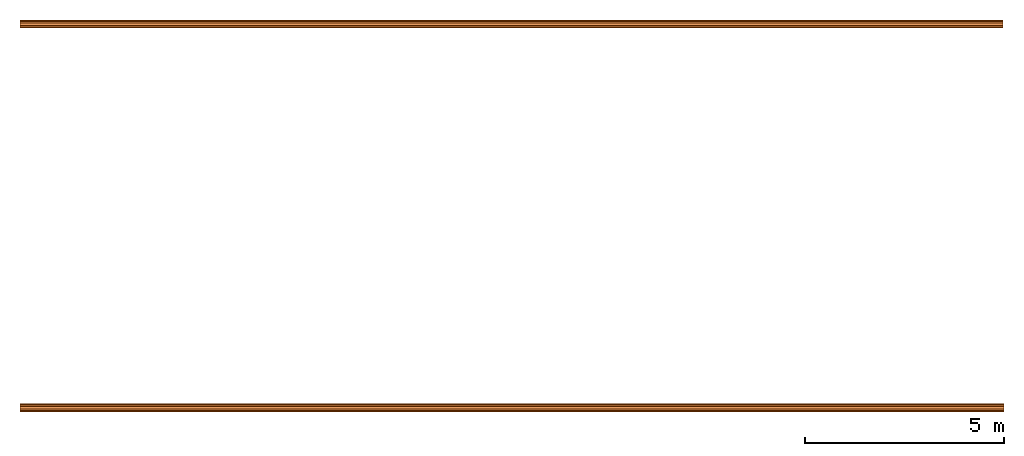
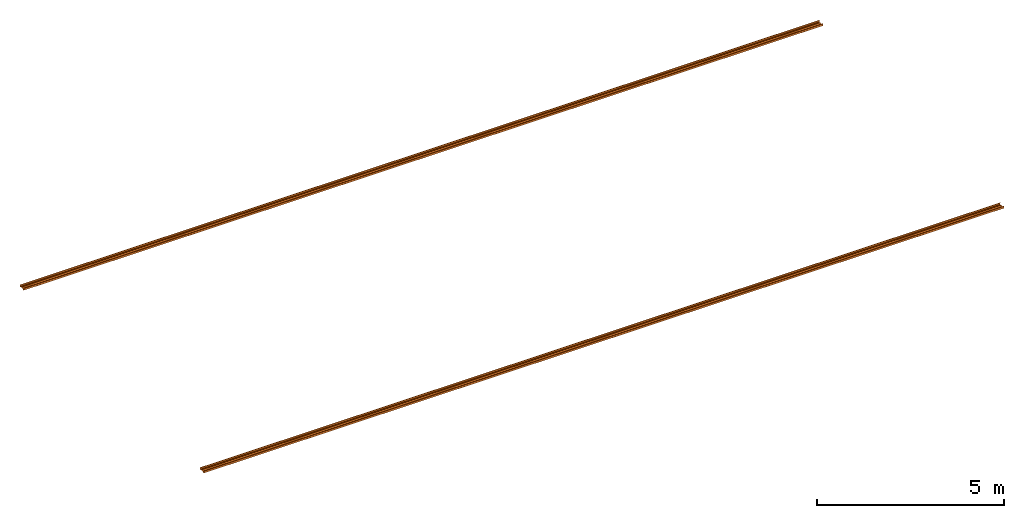
# One storey: 2 proxies.
"""IFC2X3 building model written with IfcOpenShell, lengths in millimetres."""

from ifc_helpers import new_model, entity, si_unit, converted_unit, money_unit, direction, frame, origin_with_axes, place, context, subcontext, project, spatial, faceted_brep, material, type_object, element, save


model = new_model("IFC2X3")

# Units and contexts
model_context = context("Model", 3, precision=1e-05, world=origin_with_axes(), true_north=direction((0.0, 1.0)))
body_context = subcontext(model_context, "Body", "Model", "MODEL_VIEW")
ifc_project = project(units=[si_unit("LENGTHUNIT", "METRE", prefix="MILLI"), si_unit("AREAUNIT", "SQUARE_METRE"), si_unit("VOLUMEUNIT", "CUBIC_METRE"), converted_unit("PLANEANGLEUNIT", "DEGREE", entity("IfcPlaneAngleMeasure", 0.0174532925199), si_unit("PLANEANGLEUNIT", "RADIAN"), dimensions=[0, 0, 0, 0, 0, 0, 0]), si_unit("SOLIDANGLEUNIT", "STERADIAN"), money_unit("USD"), converted_unit("TIMEUNIT", "Year", entity("IfcTimeMeasure", 31556926.0), si_unit("TIMEUNIT", "SECOND"), dimensions=[0, 0, 0, 0, 0, 0, 0]), si_unit("MASSUNIT", "GRAM"), si_unit("THERMODYNAMICTEMPERATUREUNIT", "DEGREE_CELSIUS"), si_unit("LUMINOUSINTENSITYUNIT", "LUMEN")], contexts=[model_context])

# Site, building, storey
site_placement = place(None, origin_with_axes())
site = spatial("IfcSite", under=ifc_project, at=site_placement, CompositionType="ELEMENT")
building_placement = place(site_placement, origin_with_axes())
building = spatial("IfcBuilding", under=site, at=building_placement, CompositionType="ELEMENT")
storey_placement = place(building_placement, frame((0.0, 0.0, 74190.0), z_axis=(0.0, 0.0, 1.0), x_axis=(1.0, 0.0, 0.0)))
storey = spatial("IfcBuildingStorey", under=building, at=storey_placement, Name="Eaves Level", CompositionType="ELEMENT", Elevation=74190.0)

# Proxies
ifc_material = material(Name="Metal - Steel 43-275")
building_element_proxy_type_1 = type_object("IfcBuildingElementProxyType", Name="M", PredefinedType="USERDEFINED")
proxy_1_placement = place(storey_placement, frame((4212.62953869, -1249.82006319, -1390.0), z_axis=(0.0, 0.0, 1.0), x_axis=(1.0, 0.0, 0.0)))
element("IfcBuildingElementProxy", 1, at=proxy_1_placement, inside=storey, type_object=building_element_proxy_type_1, material=ifc_material, Name="Light Gauge-Kingspan Rails:M", ObjectType="M", context=body_context, shape_type="Brep", body=[
    faceted_brep([(-12447.5, 70.5, 0.0), (-12447.5, 99.3, 0.0), (12311.5, 99.3, 0.0), (12311.5, 70.5, 0.0), (-12447.5, 32.5, 20.0), (-12447.5, -32.5, 20.0), (-12447.5, -70.5, 0.0), (-12447.5, -99.3, 0.0), (-12447.5, -100.524586984, 0.24358549596), (-12447.5, -101.5627417, 0.9372583002), (-12447.5, -102.256414504, 1.97541301643), (-12447.5, -102.5, 3.2), (-12447.5, -102.5, 61.8), (-12447.5, -102.256414504, 63.0245869836), (-12447.5, -101.5627417, 64.0627416998), (-12447.5, -100.524586984, 64.756414504), (-12447.5, -99.3, 65.0), (-12447.5, -91.7, 65.0), (-12447.5, -90.4754130164, 64.756414504), (-12447.5, -89.4372583002, 64.0627416998), (-12447.5, -88.743585496, 63.0245869836), (-12447.5, -88.5, 61.8), (-12447.5, -88.5, 53.0), (-12447.5, -90.1, 53.0), (-12447.5, -90.1, 61.8), (-12447.5, -90.221792748, 62.4122934918), (-12447.5, -90.5686291501, 62.9313708499), (-12447.5, -91.0877065082, 63.278207252), (-12447.5, -91.7, 63.4), (-12447.5, -99.3, 63.4), (-12447.5, -99.9122934918, 63.278207252), (-12447.5, -100.43137085, 62.9313708499), (-12447.5, -100.778207252, 62.4122934918), (-12447.5, -100.9, 61.8), (-12447.5, -100.9, 3.2), (-12447.5, -100.778207252, 2.58770650822), (-12447.5, -100.43137085, 2.0686291501), (-12447.5, -99.9122934918, 1.72179274798), (-12447.5, -99.3, 1.6), (-12447.5, -70.8953456886, 1.6), (-12447.5, -32.8953456886, 21.6), (-12447.5, 32.8953456886, 21.6), (-12447.5, 70.8953456886, 1.6), (-12447.5, 99.3, 1.6), (-12447.5, 99.9122934918, 1.72179274798), (-12447.5, 100.43137085, 2.0686291501), (-12447.5, 100.778207252, 2.58770650822), (-12447.5, 100.9, 3.2), (-12447.5, 100.9, 61.8), (-12447.5, 100.778207252, 62.4122934918), (-12447.5, 100.43137085, 62.9313708499), (-12447.5, 99.9122934918, 63.278207252), (-12447.5, 99.3, 63.4), (-12447.5, 91.7, 63.4), (-12447.5, 91.0877065082, 63.278207252), (-12447.5, 90.5686291501, 62.9313708499), (-12447.5, 90.221792748, 62.4122934918), (-12447.5, 90.1, 61.8), (-12447.5, 90.1, 53.0), (-12447.5, 88.5, 53.0), (-12447.5, 88.5, 61.8), (-12447.5, 88.743585496, 63.0245869836), (-12447.5, 89.4372583002, 64.0627416998), (-12447.5, 90.4754130164, 64.756414504), (-12447.5, 91.7, 65.0), (-12447.5, 99.3, 65.0), (-12447.5, 100.524586984, 64.756414504), (-12447.5, 101.5627417, 64.0627416998), (-12447.5, 102.256414504, 63.0245869836), (-12447.5, 102.5, 61.8), (-12447.5, 102.5, 3.2), (-12447.5, 102.256414504, 1.97541301643), (-12447.5, 101.5627417, 0.9372583002), (-12447.5, 100.524586984, 0.24358549596), (12311.5, 100.524586984, 0.24358549596), (12311.5, 101.5627417, 0.9372583002), (12311.5, 102.256414504, 1.97541301643), (12311.5, 102.5, 3.2), (12311.5, 102.5, 61.8), (12311.5, 102.256414504, 63.0245869836), (12311.5, 101.5627417, 64.0627416998), (12311.5, 100.524586984, 64.756414504), (12311.5, 99.3, 65.0), (12311.5, 91.7, 65.0), (12311.5, 90.4754130164, 64.756414504), (12311.5, 89.4372583002, 64.0627416998), (12311.5, 88.743585496, 63.0245869836), (12311.5, 88.5, 61.8), (12311.5, 88.5, 53.0), (12311.5, 90.1, 53.0), (12311.5, 90.1, 61.8), (12311.5, 90.221792748, 62.4122934918), (12311.5, 90.5686291501, 62.9313708499), (12311.5, 91.0877065082, 63.278207252), (12311.5, 91.7, 63.4), (12311.5, 99.3, 63.4), (12311.5, 99.9122934918, 63.278207252), (12311.5, 100.43137085, 62.9313708499), (12311.5, 100.778207252, 62.4122934918), (12311.5, 100.9, 61.8), (12311.5, 100.9, 3.2), (12311.5, 100.778207252, 2.58770650822), (12311.5, 100.43137085, 2.0686291501), (12311.5, 99.9122934918, 1.72179274798), (12311.5, 99.3, 1.6), (12311.5, 70.8953456886, 1.6), (12311.5, 32.8953456886, 21.6), (12311.5, -32.8953456886, 21.6), (12311.5, -70.8953456886, 1.6), (12311.5, -99.3, 1.6), (12311.5, -99.9122934918, 1.72179274798), (12311.5, -100.43137085, 2.0686291501), (12311.5, -100.778207252, 2.58770650822), (12311.5, -100.9, 3.2), (12311.5, -100.9, 61.8), (12311.5, -100.778207252, 62.4122934918), (12311.5, -100.43137085, 62.9313708499), (12311.5, -99.9122934918, 63.278207252), (12311.5, -99.3, 63.4), (12311.5, -91.7, 63.4), (12311.5, -91.0877065082, 63.278207252), (12311.5, -90.5686291501, 62.9313708499), (12311.5, -90.221792748, 62.4122934918), (12311.5, -90.1, 61.8), (12311.5, -90.1, 53.0), (12311.5, -88.5, 53.0), (12311.5, -88.5, 61.8), (12311.5, -88.743585496, 63.0245869836), (12311.5, -89.4372583002, 64.0627416998), (12311.5, -90.4754130164, 64.756414504), (12311.5, -91.7, 65.0), (12311.5, -99.3, 65.0), (12311.5, -100.524586984, 64.756414504), (12311.5, -101.5627417, 64.0627416998), (12311.5, -102.256414504, 63.0245869836), (12311.5, -102.5, 61.8), (12311.5, -102.5, 3.2), (12311.5, -102.256414504, 1.97541301643), (12311.5, -101.5627417, 0.9372583002), (12311.5, -100.524586984, 0.24358549596), (12311.5, -99.3, 0.0), (12311.5, -70.5, 0.0), (12311.5, -32.5, 20.0), (12311.5, 32.5, 20.0)], [[[0, 1, 2, 3]], [[0, 4, 5, 6, 7, 8, 9, 10, 11, 12, 13, 14, 15, 16, 17, 18, 19, 20, 21, 22, 23, 24, 25, 26, 27, 28, 29, 30, 31, 32, 33, 34, 35, 36, 37, 38, 39, 40, 41, 42, 43, 44, 45, 46, 47, 48, 49, 50, 51, 52, 53, 54, 55, 56, 57, 58, 59, 60, 61, 62, 63, 64, 65, 66, 67, 68, 69, 70, 71, 72, 73, 1]], [[1, 73, 74, 2]], [[3, 2, 74, 75, 76, 77, 78, 79, 80, 81, 82, 83, 84, 85, 86, 87, 88, 89, 90, 91, 92, 93, 94, 95, 96, 97, 98, 99, 100, 101, 102, 103, 104, 105, 106, 107, 108, 109, 110, 111, 112, 113, 114, 115, 116, 117, 118, 119, 120, 121, 122, 123, 124, 125, 126, 127, 128, 129, 130, 131, 132, 133, 134, 135, 136, 137, 138, 139, 140, 141, 142, 143]], [[4, 0, 3, 143]], [[5, 4, 143, 142]], [[6, 5, 142, 141]], [[7, 6, 141, 140]], [[8, 7, 140, 139]], [[9, 8, 139, 138]], [[10, 9, 138, 137]], [[11, 10, 137, 136]], [[12, 11, 136, 135]], [[13, 12, 135, 134]], [[14, 13, 134, 133]], [[15, 14, 133, 132]], [[16, 15, 132, 131]], [[17, 16, 131, 130]], [[18, 17, 130, 129]], [[19, 18, 129, 128]], [[20, 19, 128, 127]], [[21, 20, 127, 126]], [[22, 21, 126, 125]], [[23, 22, 125, 124]], [[24, 23, 124, 123]], [[25, 24, 123, 122]], [[26, 25, 122, 121]], [[27, 26, 121, 120]], [[28, 27, 120, 119]], [[29, 28, 119, 118]], [[30, 29, 118, 117]], [[31, 30, 117, 116]], [[32, 31, 116, 115]], [[33, 32, 115, 114]], [[34, 33, 114, 113]], [[35, 34, 113, 112]], [[36, 35, 112, 111]], [[37, 36, 111, 110]], [[38, 37, 110, 109]], [[39, 38, 109, 108]], [[40, 39, 108, 107]], [[41, 40, 107, 106]], [[42, 41, 106, 105]], [[43, 42, 105, 104]], [[44, 43, 104, 103]], [[45, 44, 103, 102]], [[46, 45, 102, 101]], [[47, 46, 101, 100]], [[48, 47, 100, 99]], [[49, 48, 99, 98]], [[50, 49, 98, 97]], [[51, 50, 97, 96]], [[52, 51, 96, 95]], [[53, 52, 95, 94]], [[54, 53, 94, 93]], [[55, 54, 93, 92]], [[56, 55, 92, 91]], [[57, 56, 91, 90]], [[58, 57, 90, 89]], [[59, 58, 89, 88]], [[60, 59, 88, 87]], [[61, 60, 87, 86]], [[62, 61, 86, 85]], [[63, 62, 85, 84]], [[64, 63, 84, 83]], [[65, 64, 83, 82]], [[66, 65, 82, 81]], [[67, 66, 81, 80]], [[68, 67, 80, 79]], [[69, 68, 79, 78]], [[70, 69, 78, 77]], [[71, 70, 77, 76]], [[72, 71, 76, 75]], [[73, 72, 75, 74]]]),
])
building_element_proxy_type_2 = type_object("IfcBuildingElementProxyType", Name="M", PredefinedType="USERDEFINED")
proxy_2_placement = place(storey_placement, frame((4247.8295385, 8404.77990658, -1265.0), z_axis=(0.0, 0.0, 1.0), x_axis=(1.0, 0.0, 0.0)))
element("IfcBuildingElementProxy", 2, at=proxy_2_placement, inside=storey, type_object=building_element_proxy_type_2, material=ifc_material, Name="Light Gauge-Kingspan Rails:M", ObjectType="M", context=body_context, shape_type="Brep", body=[
    faceted_brep([(12251.5, -70.5, 0.0), (12251.5, -99.3, 0.0), (-12482.5, -99.3, 0.0), (-12482.5, -70.5, 0.0), (12251.5, -32.5, 20.0), (12251.5, 32.5, 20.0), (12251.5, 70.5, 0.0), (12251.5, 99.3, 0.0), (12251.5, 100.524586984, 0.24358549596), (12251.5, 101.5627417, 0.9372583002), (12251.5, 102.256414504, 1.97541301643), (12251.5, 102.5, 3.2), (12251.5, 102.5, 61.8), (12251.5, 102.256414504, 63.0245869836), (12251.5, 101.5627417, 64.0627416998), (12251.5, 100.524586984, 64.756414504), (12251.5, 99.3, 65.0), (12251.5, 91.7, 65.0), (12251.5, 90.4754130164, 64.756414504), (12251.5, 89.4372583002, 64.0627416998), (12251.5, 88.743585496, 63.0245869836), (12251.5, 88.5, 61.8), (12251.5, 88.5, 53.0), (12251.5, 90.1, 53.0), (12251.5, 90.1, 61.8), (12251.5, 90.221792748, 62.4122934918), (12251.5, 90.5686291501, 62.9313708499), (12251.5, 91.0877065082, 63.278207252), (12251.5, 91.7, 63.4), (12251.5, 99.3, 63.4), (12251.5, 99.9122934918, 63.278207252), (12251.5, 100.43137085, 62.9313708499), (12251.5, 100.778207252, 62.4122934918), (12251.5, 100.9, 61.8), (12251.5, 100.9, 3.19999999999), (12251.5, 100.778207252, 2.58770650821), (12251.5, 100.43137085, 2.0686291501), (12251.5, 99.9122934918, 1.72179274798), (12251.5, 99.3, 1.6), (12251.5, 70.8953456886, 1.6), (12251.5, 32.8953456886, 21.6), (12251.5, -32.8953456886, 21.6), (12251.5, -70.8953456886, 1.6), (12251.5, -99.3, 1.6), (12251.5, -99.9122934918, 1.72179274798), (12251.5, -100.43137085, 2.0686291501), (12251.5, -100.778207252, 2.58770650821), (12251.5, -100.9, 3.19999999999), (12251.5, -100.9, 61.8), (12251.5, -100.778207252, 62.4122934918), (12251.5, -100.43137085, 62.9313708499), (12251.5, -99.9122934918, 63.278207252), (12251.5, -99.3, 63.4), (12251.5, -91.7, 63.4), (12251.5, -91.0877065082, 63.278207252), (12251.5, -90.5686291501, 62.9313708499), (12251.5, -90.221792748, 62.4122934918), (12251.5, -90.1, 61.8), (12251.5, -90.1, 53.0), (12251.5, -88.5, 53.0), (12251.5, -88.5, 61.8), (12251.5, -88.743585496, 63.0245869836), (12251.5, -89.4372583002, 64.0627416998), (12251.5, -90.4754130164, 64.756414504), (12251.5, -91.7, 65.0), (12251.5, -99.3, 65.0), (12251.5, -100.524586984, 64.756414504), (12251.5, -101.5627417, 64.0627416998), (12251.5, -102.256414504, 63.0245869836), (12251.5, -102.5, 61.8), (12251.5, -102.5, 3.19999999999), (12251.5, -102.256414504, 1.97541301643), (12251.5, -101.5627417, 0.9372583002), (12251.5, -100.524586984, 0.24358549596), (-12482.5, -100.524586984, 0.24358549596), (-12482.5, -101.5627417, 0.9372583002), (-12482.5, -102.256414504, 1.97541301643), (-12482.5, -102.5, 3.19999999999), (-12482.5, -102.5, 61.8), (-12482.5, -102.256414504, 63.0245869836), (-12482.5, -101.5627417, 64.0627416998), (-12482.5, -100.524586984, 64.756414504), (-12482.5, -99.3, 65.0), (-12482.5, -91.7, 65.0), (-12482.5, -90.4754130164, 64.756414504), (-12482.5, -89.4372583002, 64.0627416998), (-12482.5, -88.743585496, 63.0245869836), (-12482.5, -88.5, 61.8), (-12482.5, -88.5, 53.0), (-12482.5, -90.1, 53.0), (-12482.5, -90.1, 61.8), (-12482.5, -90.221792748, 62.4122934918), (-12482.5, -90.5686291501, 62.9313708499), (-12482.5, -91.0877065082, 63.278207252), (-12482.5, -91.7, 63.4), (-12482.5, -99.3, 63.4), (-12482.5, -99.9122934918, 63.278207252), (-12482.5, -100.43137085, 62.9313708499), (-12482.5, -100.778207252, 62.4122934918), (-12482.5, -100.9, 61.8), (-12482.5, -100.9, 3.19999999999), (-12482.5, -100.778207252, 2.58770650821), (-12482.5, -100.43137085, 2.0686291501), (-12482.5, -99.9122934918, 1.72179274798), (-12482.5, -99.3, 1.6), (-12482.5, -70.8953456886, 1.6), (-12482.5, -32.8953456886, 21.6), (-12482.5, 32.8953456886, 21.6), (-12482.5, 70.8953456886, 1.6), (-12482.5, 99.3, 1.6), (-12482.5, 99.9122934918, 1.72179274798), (-12482.5, 100.43137085, 2.0686291501), (-12482.5, 100.778207252, 2.58770650821), (-12482.5, 100.9, 3.19999999999), (-12482.5, 100.9, 61.8), (-12482.5, 100.778207252, 62.4122934918), (-12482.5, 100.43137085, 62.9313708499), (-12482.5, 99.9122934918, 63.278207252), (-12482.5, 99.3, 63.4), (-12482.5, 91.7, 63.4), (-12482.5, 91.0877065082, 63.278207252), (-12482.5, 90.5686291501, 62.9313708499), (-12482.5, 90.221792748, 62.4122934918), (-12482.5, 90.1, 61.8), (-12482.5, 90.1, 53.0), (-12482.5, 88.5, 53.0), (-12482.5, 88.5, 61.8), (-12482.5, 88.743585496, 63.0245869836), (-12482.5, 89.4372583002, 64.0627416998), (-12482.5, 90.4754130164, 64.756414504), (-12482.5, 91.7, 65.0), (-12482.5, 99.3, 65.0), (-12482.5, 100.524586984, 64.756414504), (-12482.5, 101.5627417, 64.0627416998), (-12482.5, 102.256414504, 63.0245869836), (-12482.5, 102.5, 61.8), (-12482.5, 102.5, 3.2), (-12482.5, 102.256414504, 1.97541301643), (-12482.5, 101.5627417, 0.9372583002), (-12482.5, 100.524586984, 0.24358549596), (-12482.5, 99.3, 0.0), (-12482.5, 70.5, 0.0), (-12482.5, 32.5, 20.0), (-12482.5, -32.5, 20.0)], [[[0, 1, 2, 3]], [[0, 4, 5, 6, 7, 8, 9, 10, 11, 12, 13, 14, 15, 16, 17, 18, 19, 20, 21, 22, 23, 24, 25, 26, 27, 28, 29, 30, 31, 32, 33, 34, 35, 36, 37, 38, 39, 40, 41, 42, 43, 44, 45, 46, 47, 48, 49, 50, 51, 52, 53, 54, 55, 56, 57, 58, 59, 60, 61, 62, 63, 64, 65, 66, 67, 68, 69, 70, 71, 72, 73, 1]], [[1, 73, 74, 2]], [[3, 2, 74, 75, 76, 77, 78, 79, 80, 81, 82, 83, 84, 85, 86, 87, 88, 89, 90, 91, 92, 93, 94, 95, 96, 97, 98, 99, 100, 101, 102, 103, 104, 105, 106, 107, 108, 109, 110, 111, 112, 113, 114, 115, 116, 117, 118, 119, 120, 121, 122, 123, 124, 125, 126, 127, 128, 129, 130, 131, 132, 133, 134, 135, 136, 137, 138, 139, 140, 141, 142, 143]], [[4, 0, 3, 143]], [[5, 4, 143, 142]], [[6, 5, 142, 141]], [[7, 6, 141, 140]], [[8, 7, 140, 139]], [[9, 8, 139, 138]], [[10, 9, 138, 137]], [[11, 10, 137, 136]], [[12, 11, 136, 135]], [[13, 12, 135, 134]], [[14, 13, 134, 133]], [[15, 14, 133, 132]], [[16, 15, 132, 131]], [[17, 16, 131, 130]], [[18, 17, 130, 129]], [[19, 18, 129, 128]], [[20, 19, 128, 127]], [[21, 20, 127, 126]], [[22, 21, 126, 125]], [[23, 22, 125, 124]], [[24, 23, 124, 123]], [[25, 24, 123, 122]], [[26, 25, 122, 121]], [[27, 26, 121, 120]], [[28, 27, 120, 119]], [[29, 28, 119, 118]], [[30, 29, 118, 117]], [[31, 30, 117, 116]], [[32, 31, 116, 115]], [[33, 32, 115, 114]], [[34, 33, 114, 113]], [[35, 34, 113, 112]], [[36, 35, 112, 111]], [[37, 36, 111, 110]], [[38, 37, 110, 109]], [[39, 38, 109, 108]], [[40, 39, 108, 107]], [[41, 40, 107, 106]], [[42, 41, 106, 105]], [[43, 42, 105, 104]], [[44, 43, 104, 103]], [[45, 44, 103, 102]], [[46, 45, 102, 101]], [[47, 46, 101, 100]], [[48, 47, 100, 99]], [[49, 48, 99, 98]], [[50, 49, 98, 97]], [[51, 50, 97, 96]], [[52, 51, 96, 95]], [[53, 52, 95, 94]], [[54, 53, 94, 93]], [[55, 54, 93, 92]], [[56, 55, 92, 91]], [[57, 56, 91, 90]], [[58, 57, 90, 89]], [[59, 58, 89, 88]], [[60, 59, 88, 87]], [[61, 60, 87, 86]], [[62, 61, 86, 85]], [[63, 62, 85, 84]], [[64, 63, 84, 83]], [[65, 64, 83, 82]], [[66, 65, 82, 81]], [[67, 66, 81, 80]], [[68, 67, 80, 79]], [[69, 68, 79, 78]], [[70, 69, 78, 77]], [[71, 70, 77, 76]], [[72, 71, 76, 75]], [[73, 72, 75, 74]]]),
])

save(model, "model.ifc")
